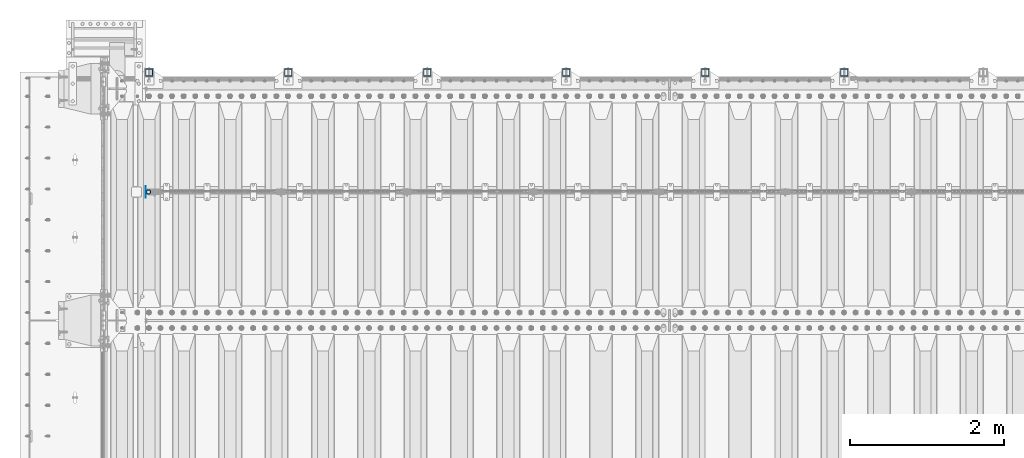
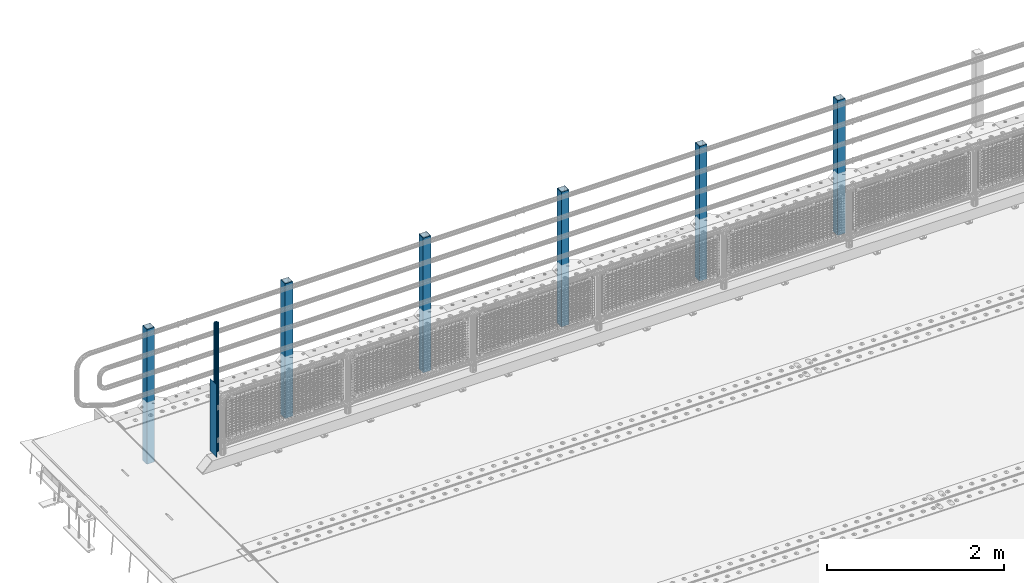
# One storey, part 62 of 270: 8 columns.
"""IFC2X3 building model written with IfcOpenShell, lengths in millimetres."""

from ifc_helpers import new_model, si_unit, frame, origin_with_axes, place, context, subcontext, project, spatial, faceted_brep, material, type_object, element, save


model = new_model("IFC2X3")

# Units and contexts
model_context = context("Model", 3, precision=1e-05, world=origin_with_axes())
body_context = subcontext(model_context, "Body", "Model", "MODEL_VIEW")
ifc_project = project(units=[si_unit("LENGTHUNIT", "METRE", prefix="MILLI"), si_unit("AREAUNIT", "SQUARE_METRE"), si_unit("VOLUMEUNIT", "CUBIC_METRE"), si_unit("MASSUNIT", "GRAM", prefix="KILO"), si_unit("TIMEUNIT", "SECOND"), si_unit("PLANEANGLEUNIT", "RADIAN"), si_unit("SOLIDANGLEUNIT", "STERADIAN"), si_unit("THERMODYNAMICTEMPERATUREUNIT", "DEGREE_CELSIUS"), si_unit("LUMINOUSINTENSITYUNIT", "LUMEN")], contexts=[model_context])

# Site, building, storey
site_placement = place(None, origin_with_axes())
site = spatial("IfcSite", under=ifc_project, at=site_placement, CompositionType="ELEMENT")
building_placement = place(site_placement, origin_with_axes())
building = spatial("IfcBuilding", under=site, at=building_placement, Name="Standard", CompositionType="ELEMENT")
storey_placement = place(building_placement, origin_with_axes())
storey = spatial("IfcBuildingStorey", under=building, at=storey_placement, Name="Undefined", CompositionType="ELEMENT", Elevation=0.0)

# Columns
ifc_material_1 = material(Name="Misc_Undefined")
column_type_1 = type_object("IfcColumnType", PredefinedType="NOTDEFINED")
column_1_placement = place(storey_placement, frame((504.5, -16335.5, 200.0), z_axis=(0.0, 1.0, 0.0), x_axis=(0.0, 0.0, 1.0)))
element("IfcColumn", 1, at=column_1_placement, inside=storey, type_object=column_type_1, material=ifc_material_1, context=body_context, shape_type="Brep", body=[
    faceted_brep([(0.0, 1.5, -75.0), (0.0, 1.5, 75.0), (1000.0, 1.5, 75.0), (1000.0, 1.5, -75.0), (0.0, -1.5, 75.0), (1000.0, -1.5, 75.0), (0.0, -1.5, -75.0), (1000.0, -1.5, -75.0)], [[[0, 1, 2, 3]], [[1, 4, 5, 2]], [[4, 6, 7, 5]], [[6, 0, 3, 7]], [[5, 7, 3, 2]], [[6, 4, 1, 0]]]),
])
column_type_2 = type_object("IfcColumnType", PredefinedType="NOTDEFINED")
column_2_placement = place(storey_placement, frame((541.0, -16335.5, 238.020000000001), z_axis=(1.0, 0.0, 0.0), x_axis=(0.0, 0.0, 1.0)))
element("IfcColumn", 2, at=column_2_placement, inside=storey, type_object=column_type_2, material=ifc_material_1, context=body_context, shape_type="Brep", body=[
    faceted_brep([(0.0, -25.3500000000004, 0.0), (0.0, -23.4203461491616, 9.70102501045403), (1761.98, -23.4203461491616, 9.70102501045403), (1761.98, -25.3500000000004, 0.0), (0.0, -17.9251569030785, 17.9251569030785), (1761.98, -17.9251569030785, 17.9251569030785), (0.0, -9.70102501045585, 23.4203461491597), (1761.98, -9.70102501045585, 23.4203461491597), (0.0, 0.0, 25.3499999999985), (1761.98, 0.0, 25.3499999999985), (0.0, 9.70102501045585, 23.4203461491597), (1761.98, 9.70102501045585, 23.4203461491597), (0.0, 17.9251569030785, 17.9251569030785), (1761.98, 17.9251569030785, 17.9251569030785), (0.0, 23.4203461491616, 9.70102501045403), (1761.98, 23.4203461491616, 9.70102501045403), (0.0, 25.3500000000004, 0.0), (1761.98, 25.3500000000004, 0.0), (0.0, 23.4203461491616, -9.70102501045403), (1761.98, 23.4203461491616, -9.70102501045403), (0.0, 17.9251569030785, -17.9251569030785), (1761.98, 17.9251569030785, -17.9251569030785), (0.0, 9.70102501045585, -23.4203461491597), (1761.98, 9.70102501045585, -23.4203461491597), (0.0, 0.0, -25.3499999999985), (1761.98, 0.0, -25.3499999999985), (0.0, -9.70102501045585, -23.4203461491597), (1761.98, -9.70102501045585, -23.4203461491597), (0.0, -17.9251569030785, -17.9251569030785), (1761.98, -17.9251569030785, -17.9251569030785), (0.0, -23.4203461491616, -9.70102501045403), (1761.98, -23.4203461491616, -9.70102501045403), (0.0, -30.1499999999996, 0.0), (0.0, -27.8549679052157, -11.5379054858058), (1761.98, -27.8549679052157, -11.5379054858058), (1761.98, -30.1499999999996, 0.0), (0.0, -21.3192694527752, -21.3192694527752), (1761.98, -21.3192694527752, -21.3192694527752), (0.0, -11.5379054858076, -27.8549679052157), (1761.98, -11.5379054858076, -27.8549679052157), (0.0, 0.0, -30.1500000000015), (1761.98, 0.0, -30.1500000000015), (0.0, 11.5379054858076, -27.8549679052157), (1761.98, 11.5379054858076, -27.8549679052157), (0.0, 21.3192694527752, -21.3192694527752), (1761.98, 21.3192694527752, -21.3192694527752), (0.0, 27.8549679052157, -11.5379054858058), (1761.98, 27.8549679052157, -11.5379054858058), (0.0, 30.1499999999996, 0.0), (1761.98, 30.1499999999996, 0.0), (0.0, 27.8549679052157, 11.5379054858058), (1761.98, 27.8549679052157, 11.5379054858058), (0.0, 21.3192694527752, 21.3192694527752), (1761.98, 21.3192694527752, 21.3192694527752), (0.0, 11.5379054858076, 27.8549679052157), (1761.98, 11.5379054858076, 27.8549679052157), (0.0, 0.0, 30.1500000000015), (1761.98, 0.0, 30.1500000000015), (0.0, -11.5379054858076, 27.8549679052157), (1761.98, -11.5379054858076, 27.8549679052157), (0.0, -21.3192694527752, 21.3192694527752), (1761.98, -21.3192694527752, 21.3192694527752), (0.0, -27.8549679052157, 11.5379054858058), (1761.98, -27.8549679052157, 11.5379054858058)], [[[0, 1, 2, 3]], [[1, 4, 5, 2]], [[4, 6, 7, 5]], [[6, 8, 9, 7]], [[8, 10, 11, 9]], [[10, 12, 13, 11]], [[12, 14, 15, 13]], [[14, 16, 17, 15]], [[16, 18, 19, 17]], [[18, 20, 21, 19]], [[20, 22, 23, 21]], [[22, 24, 25, 23]], [[24, 26, 27, 25]], [[26, 28, 29, 27]], [[28, 30, 31, 29]], [[30, 0, 3, 31]], [[32, 33, 34, 35]], [[33, 36, 37, 34]], [[36, 38, 39, 37]], [[38, 40, 41, 39]], [[40, 42, 43, 41]], [[42, 44, 45, 43]], [[44, 46, 47, 45]], [[46, 48, 49, 47]], [[48, 50, 51, 49]], [[50, 52, 53, 51]], [[52, 54, 55, 53]], [[54, 56, 57, 55]], [[56, 58, 59, 57]], [[58, 60, 61, 59]], [[60, 62, 63, 61]], [[62, 32, 35, 63]], [[37, 39, 41, 43, 45, 47, 49, 51, 53, 55, 57, 59, 61, 63, 35, 34], [5, 7, 9, 11, 13, 15, 17, 19, 21, 23, 25, 27, 29, 31, 3, 2]], [[62, 60, 58, 56, 54, 52, 50, 48, 46, 44, 42, 40, 38, 36, 33, 32], [30, 28, 26, 24, 22, 20, 18, 16, 14, 12, 10, 8, 6, 4, 1, 0]]]),
])
ifc_material_2 = material()
column_type_3 = type_object("IfcColumnType", PredefinedType="NOTDEFINED")
for number, where, z_axis, x_axis in (
    (3, (9550.00000000013, -14789.9999999998, -844.999999999998), (0.0, -1.0, 0.0), (0.0, 0.0, 1.0)),
    (4, (7750.00000000013, -14789.9999999998, -844.999999999998), (0.0, -1.0, 0.0), (0.0, 0.0, 1.0)),
    (5, (5950.00000000013, -14789.9999999998, -844.999999999998), (0.0, -1.0, 0.0), (0.0, 0.0, 1.0)),
    (6, (4150.00000000013, -14789.9999999998, -844.999999999998), (0.0, -1.0, 0.0), (0.0, 0.0, 1.0)),
    (7, (2350.00000000013, -14789.9999999998, -844.999999999998), (0.0, -1.0, 0.0), (0.0, 0.0, 1.0)),
    (8, (550.000000000131, -14789.9999999998, -844.999999999998), (0.0, -1.0, 0.0), (0.0, 0.0, 1.0)),
):
    element("IfcColumn", number, at=place(storey_placement, frame(where, z_axis=z_axis, x_axis=x_axis)), inside=storey, type_object=column_type_3, material=ifc_material_2, context=body_context, shape_type="Brep", body=[
        faceted_brep([(0.0, 40.0, -40.0), (0.0, -40.0, -40.0), (1855.0, -40.0, -40.0), (1855.0, 40.0, -40.0), (0.0, -40.0, 40.0), (1855.0, -40.0, 40.0), (0.0, 40.0, 40.0), (1855.0, 40.0, 40.0), (0.0, 50.0, -50.0), (0.0, 50.0, 50.0), (1855.0, 50.0, 50.0), (1855.0, 50.0, -50.0), (0.0, -50.0, 50.0), (1855.0, -50.0, 50.0), (0.0, -50.0, -50.0), (1855.0, -50.0, -50.0)], [[[0, 1, 2, 3]], [[1, 4, 5, 2]], [[4, 6, 7, 5]], [[6, 0, 3, 7]], [[8, 9, 10, 11]], [[9, 12, 13, 10]], [[12, 14, 15, 13]], [[14, 8, 11, 15]], [[13, 15, 11, 10], [5, 7, 3, 2]], [[14, 12, 9, 8], [6, 4, 1, 0]]]),
    ])

save(model, "model.ifc")
